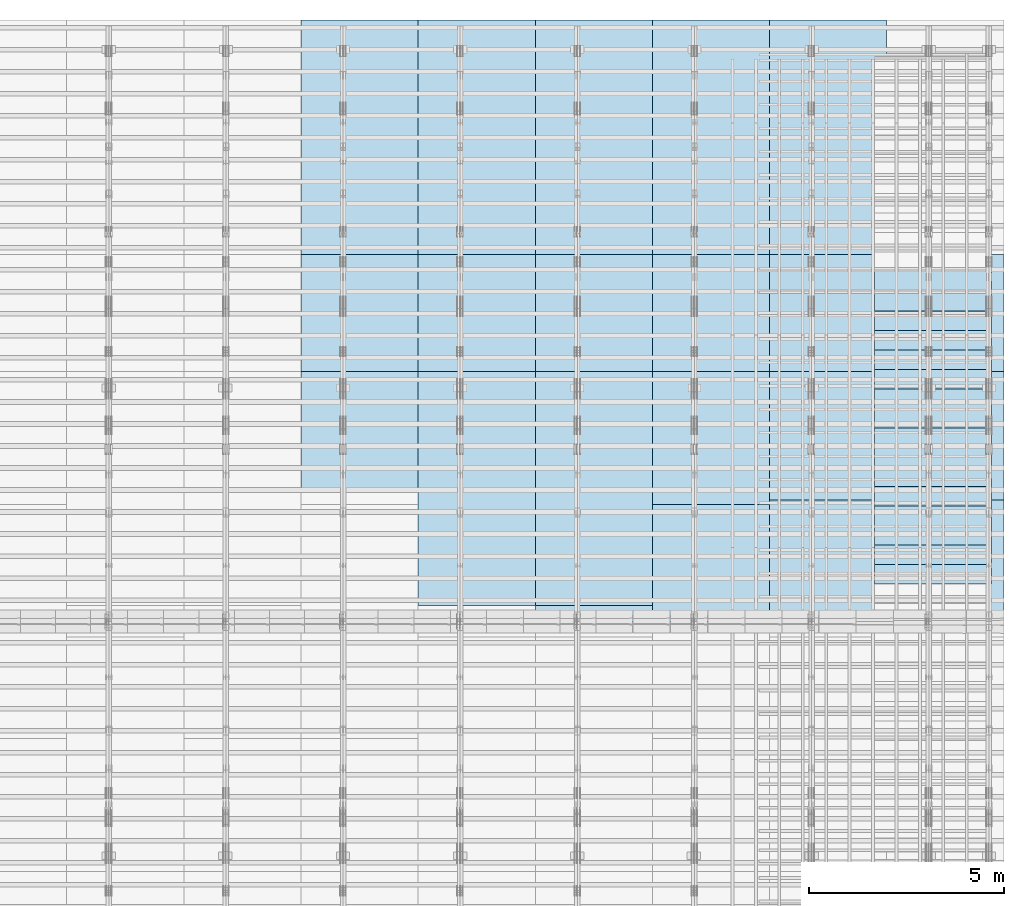
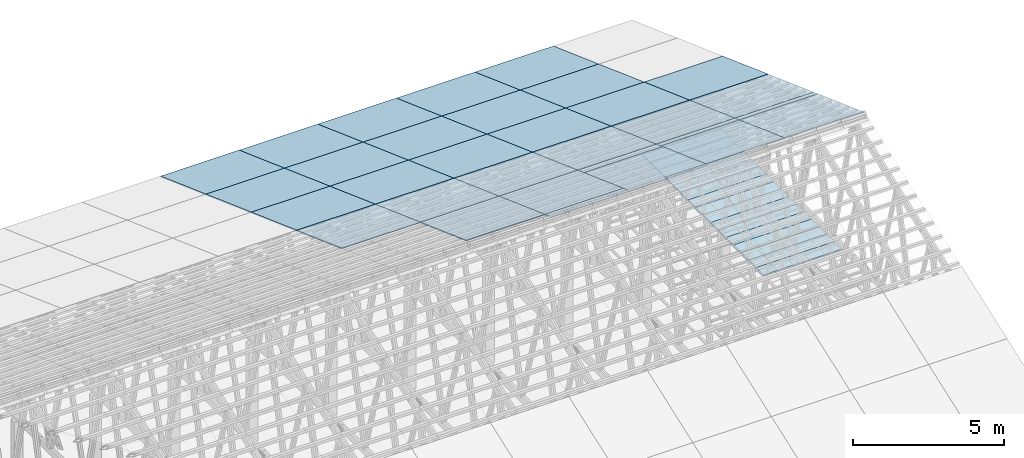
# One storey, part 10 of 189: 47 slabs, 47 elements without a shape of their own.
"""IFC2X3 building model written with IfcOpenShell, lengths in millimetres."""

from ifc_helpers import new_model, entity, si_unit, converted_unit, derived_unit, direction, frame, frame_2d, origin, origin_2d_with_axis, place, context, subcontext, project, spatial, rectangle, extrude, material, layer, layer_set, element, aggregate, save


model = new_model("IFC2X3")

# Units and contexts
model_context = context("Model", 3, precision=0.01, world=origin(), true_north=direction((6.12303176911189e-17, 1.0)))
body_context = subcontext(model_context, "Body", "Model", "MODEL_VIEW")
ifc_project = project(units=[si_unit("LENGTHUNIT", "METRE", prefix="MILLI"), si_unit("AREAUNIT", "SQUARE_METRE"), si_unit("VOLUMEUNIT", "CUBIC_METRE"), converted_unit("PLANEANGLEUNIT", "DEGREE", entity("IfcRatioMeasure", 0.0174532925199433), si_unit("PLANEANGLEUNIT", "RADIAN"), dimensions=[0, 0, 0, 0, 0, 0, 0]), si_unit("MASSUNIT", "GRAM", prefix="KILO"), derived_unit("MASSDENSITYUNIT", [(si_unit("MASSUNIT", "GRAM", prefix="KILO"), 1), (si_unit("LENGTHUNIT", "METRE"), -3)]), si_unit("TIMEUNIT", "SECOND"), si_unit("FREQUENCYUNIT", "HERTZ"), si_unit("THERMODYNAMICTEMPERATUREUNIT", "DEGREE_CELSIUS"), derived_unit("THERMALTRANSMITTANCEUNIT", [(si_unit("MASSUNIT", "GRAM", prefix="KILO"), 1), (si_unit("THERMODYNAMICTEMPERATUREUNIT", "KELVIN"), -1), (si_unit("TIMEUNIT", "SECOND"), -3)]), derived_unit("VOLUMETRICFLOWRATEUNIT", [(si_unit("LENGTHUNIT", "METRE"), 3), (si_unit("TIMEUNIT", "SECOND"), -1)]), si_unit("ELECTRICCURRENTUNIT", "AMPERE"), si_unit("ELECTRICVOLTAGEUNIT", "VOLT"), si_unit("POWERUNIT", "WATT"), si_unit("FORCEUNIT", "NEWTON"), si_unit("ILLUMINANCEUNIT", "LUX"), si_unit("LUMINOUSFLUXUNIT", "LUMEN"), si_unit("LUMINOUSINTENSITYUNIT", "CANDELA"), derived_unit("USERDEFINED", [(si_unit("MASSUNIT", "GRAM", prefix="KILO"), -1), (si_unit("LENGTHUNIT", "METRE"), -2), (si_unit("TIMEUNIT", "SECOND"), 3), (si_unit("LUMINOUSFLUXUNIT", "LUMEN"), 1)]), derived_unit("LINEARVELOCITYUNIT", [(si_unit("LENGTHUNIT", "METRE"), 1), (si_unit("TIMEUNIT", "SECOND"), -1)]), si_unit("PRESSUREUNIT", "PASCAL"), derived_unit("USERDEFINED", [(si_unit("LENGTHUNIT", "METRE"), -2), (si_unit("MASSUNIT", "GRAM", prefix="KILO"), 1), (si_unit("TIMEUNIT", "SECOND"), -2)])], contexts=[model_context])

# Site, building, storey
site_placement = place(None, origin())
site = spatial("IfcSite", under=ifc_project, at=site_placement, CompositionType="ELEMENT")
building_placement = place(site_placement, origin())
building = spatial("IfcBuilding", under=site, at=building_placement, CompositionType="ELEMENT")
storey_placement = place(building_placement, origin())
storey = spatial("IfcBuildingStorey", under=building, at=storey_placement, Name="Default", CompositionType="ELEMENT", Elevation=0.0)

# Roof, slab
roof_1_placement = place(storey_placement, frame((47153.4200853155, 21152.222636977, 2421.93662132902)))
roof_1 = element("IfcRoof", 1, at=roof_1_placement, inside=storey, ShapeType="NOTDEFINED")
ifc_material_1 = material()
ifc_layer_1 = layer(ifc_material_1, 40.0)
ifc_layer_set_1 = layer_set([ifc_layer_1])
slab_1_placement = place(roof_1_placement, origin())
slab_1 = element("IfcSlab", 2, at=slab_1_placement, material=ifc_layer_set_1, PredefinedType="ROOF", context=body_context, shape_type="SweptSolid", body=[
    extrude(rectangle(XDim=3192.53331742773, YDim=3000.0, at=frame_2d((4.32009983342141e-12, 1.13686837721616e-13), x_axis=(0.0, 1.0))), frame((1500.0, 1500.0, 545.955351399304), z_axis=(0.0, 0.342020143325669, 0.939692620785908), x_axis=(1.0, 0.0, 0.0)), (0.0, -0.342020143325669, 0.939692620785908), 42.5671108990361),
])
aggregate(roof_1, [slab_1])

roof_2_placement = place(storey_placement, frame((47153.4200853155, 18152.222636977, 3513.84732412761)))
roof_2 = element("IfcRoof", 3, at=roof_2_placement, inside=storey, ShapeType="NOTDEFINED")
slab_2_placement = place(roof_2_placement, origin())
slab_2 = element("IfcSlab", 4, at=slab_2_placement, material=ifc_layer_set_1, PredefinedType="ROOF", context=body_context, shape_type="SweptSolid", body=[
    extrude(rectangle(XDim=3192.53331742773, YDim=3000.0, at=frame_2d((4.32009983342141e-12, 0.0), x_axis=(0.0, 1.0))), frame((1500.0, 1500.0, 545.955351399303), z_axis=(0.0, 0.342020143325669, 0.939692620785908), x_axis=(1.0, 0.0, 0.0)), (0.0, -0.342020143325669, 0.939692620785908), 42.5671108990366),
])
aggregate(roof_2, [slab_2])

roof_3_placement = place(storey_placement, frame((47153.4200853155, 15152.222636977, 4605.75802692621)))
roof_3 = element("IfcRoof", 5, at=roof_3_placement, inside=storey, ShapeType="NOTDEFINED")
slab_3_placement = place(roof_3_placement, origin())
slab_3 = element("IfcSlab", 6, at=slab_3_placement, material=ifc_layer_set_1, PredefinedType="ROOF", context=body_context, shape_type="SweptSolid", body=[
    extrude(rectangle(XDim=3192.53331742773, YDim=3000.0, at=frame_2d((4.32009983342141e-12, -1.13686837721616e-13), x_axis=(0.0, 1.0))), frame((1500.0, 1500.0, 545.955351399304), z_axis=(0.0, 0.342020143325669, 0.939692620785908), x_axis=(1.0, 0.0, 0.0)), (0.0, -0.342020143325669, 0.939692620785908), 42.5671108990361),
])
aggregate(roof_3, [slab_3])

roof_4_placement = place(storey_placement, frame((47153.4200853155, 14853.3662321495, 4714.53286260321)))
roof_4 = element("IfcRoof", 7, at=roof_4_placement, inside=storey, ShapeType="NOTDEFINED")
slab_4_placement = place(roof_4_placement, origin())
slab_4 = element("IfcSlab", 8, at=slab_4_placement, material=ifc_layer_set_1, PredefinedType="ROOF", context=body_context, shape_type="SweptSolid", body=[
    extrude(rectangle(XDim=3192.53331742773, YDim=3000.0, at=frame_2d((4.32009983342141e-12, 0.0), x_axis=(0.0, 1.0))), frame((1500.0, 1500.0, 545.955351399303), z_axis=(0.0, 0.342020143325669, 0.939692620785908), x_axis=(1.0, 0.0, 0.0)), (0.0, -0.342020143325669, 0.939692620785908), 42.5671108990372),
])
aggregate(roof_4, [slab_4])

roof_5_placement = place(storey_placement, frame((44153.4200853155, 27152.222636977, 238.115215731819)))
roof_5 = element("IfcRoof", 9, at=roof_5_placement, inside=storey, ShapeType="NOTDEFINED")
slab_5_placement = place(roof_5_placement, origin())
slab_5 = element("IfcSlab", 10, at=slab_5_placement, material=ifc_layer_set_1, PredefinedType="ROOF", context=body_context, shape_type="SweptSolid", body=[
    extrude(rectangle(XDim=3192.53331742773, YDim=2999.99999999999, at=frame_2d((0.0, 1.13686837721616e-13), x_axis=(0.0, 1.0))), frame((1500.0, 1500.0, 545.955351399304), z_axis=(0.0, 0.342020143325669, 0.939692620785908), x_axis=(1.0, 0.0, 0.0)), (0.0, -0.342020143325669, 0.939692620785908), 42.5671108990364),
])
aggregate(roof_5, [slab_5])

roof_6_placement = place(storey_placement, frame((44153.4200853155, 24152.222636977, 1330.02591853042)))
roof_6 = element("IfcRoof", 11, at=roof_6_placement, inside=storey, ShapeType="NOTDEFINED")
slab_6_placement = place(roof_6_placement, origin())
slab_6 = element("IfcSlab", 12, at=slab_6_placement, material=ifc_layer_set_1, PredefinedType="ROOF", context=body_context, shape_type="SweptSolid", body=[
    extrude(rectangle(XDim=3192.53331742773, YDim=2999.99999999999, at=frame_2d((0.0, 0.0), x_axis=(0.0, 1.0))), frame((1500.0, 1500.0, 545.955351399304), z_axis=(0.0, 0.342020143325669, 0.939692620785908), x_axis=(1.0, 0.0, 0.0)), (0.0, -0.342020143325669, 0.939692620785908), 42.5671108990358),
])
aggregate(roof_6, [slab_6])

roof_7_placement = place(storey_placement, frame((44153.4200853155, 21152.222636977, 2421.93662132902)))
roof_7 = element("IfcRoof", 13, at=roof_7_placement, inside=storey, ShapeType="NOTDEFINED")
slab_7_placement = place(roof_7_placement, origin())
slab_7 = element("IfcSlab", 14, at=slab_7_placement, material=ifc_layer_set_1, PredefinedType="ROOF", context=body_context, shape_type="SweptSolid", body=[
    extrude(rectangle(XDim=3192.53331742773, YDim=3000.0, at=frame_2d((4.32009983342141e-12, 1.13686837721616e-13), x_axis=(0.0, 1.0))), frame((1500.0, 1500.0, 545.955351399304), z_axis=(0.0, 0.342020143325669, 0.939692620785908), x_axis=(1.0, 0.0, 0.0)), (0.0, -0.342020143325669, 0.939692620785908), 42.5671108990361),
])
aggregate(roof_7, [slab_7])

roof_8_placement = place(storey_placement, frame((44153.4200853155, 18152.222636977, 3513.84732412761)))
roof_8 = element("IfcRoof", 15, at=roof_8_placement, inside=storey, ShapeType="NOTDEFINED")
slab_8_placement = place(roof_8_placement, origin())
slab_8 = element("IfcSlab", 16, at=slab_8_placement, material=ifc_layer_set_1, PredefinedType="ROOF", context=body_context, shape_type="SweptSolid", body=[
    extrude(rectangle(XDim=3192.53331742773, YDim=3000.0, at=frame_2d((4.32009983342141e-12, 0.0), x_axis=(0.0, 1.0))), frame((1500.0, 1500.0, 545.955351399303), z_axis=(0.0, 0.342020143325669, 0.939692620785908), x_axis=(1.0, 0.0, 0.0)), (0.0, -0.342020143325669, 0.939692620785908), 42.5671108990366),
])
aggregate(roof_8, [slab_8])

roof_9_placement = place(storey_placement, frame((44153.4200853155, 15152.222636977, 4605.75802692621)))
roof_9 = element("IfcRoof", 17, at=roof_9_placement, inside=storey, ShapeType="NOTDEFINED")
slab_9_placement = place(roof_9_placement, origin())
slab_9 = element("IfcSlab", 18, at=slab_9_placement, material=ifc_layer_set_1, PredefinedType="ROOF", context=body_context, shape_type="SweptSolid", body=[
    extrude(rectangle(XDim=3192.53331742773, YDim=3000.0, at=frame_2d((4.32009983342141e-12, -1.13686837721616e-13), x_axis=(0.0, 1.0))), frame((1500.0, 1500.0, 545.955351399304), z_axis=(0.0, 0.342020143325669, 0.939692620785908), x_axis=(1.0, 0.0, 0.0)), (0.0, -0.342020143325669, 0.939692620785908), 42.5671108990361),
])
aggregate(roof_9, [slab_9])

roof_10_placement = place(storey_placement, frame((44153.4200853155, 14853.3662321495, 4714.53286260321)))
roof_10 = element("IfcRoof", 19, at=roof_10_placement, inside=storey, ShapeType="NOTDEFINED")
slab_10_placement = place(roof_10_placement, origin())
slab_10 = element("IfcSlab", 20, at=slab_10_placement, material=ifc_layer_set_1, PredefinedType="ROOF", context=body_context, shape_type="SweptSolid", body=[
    extrude(rectangle(XDim=3192.53331742773, YDim=3000.0, at=frame_2d((4.32009983342141e-12, 0.0), x_axis=(0.0, 1.0))), frame((1500.0, 1500.0, 545.955351399303), z_axis=(0.0, 0.342020143325669, 0.939692620785908), x_axis=(1.0, 0.0, 0.0)), (0.0, -0.342020143325669, 0.939692620785908), 42.5671108990372),
])
aggregate(roof_10, [slab_10])

roof_11_placement = place(storey_placement, frame((41153.4200853155, 27152.222636977, 238.115215731819)))
roof_11 = element("IfcRoof", 21, at=roof_11_placement, inside=storey, ShapeType="NOTDEFINED")
slab_11_placement = place(roof_11_placement, origin())
slab_11 = element("IfcSlab", 22, at=slab_11_placement, material=ifc_layer_set_1, PredefinedType="ROOF", context=body_context, shape_type="SweptSolid", body=[
    extrude(rectangle(XDim=3192.53331742773, YDim=2999.99999999999, at=frame_2d((0.0, 1.13686837721616e-13), x_axis=(0.0, 1.0))), frame((1500.0, 1500.0, 545.955351399304), z_axis=(0.0, 0.342020143325669, 0.939692620785908), x_axis=(1.0, 0.0, 0.0)), (0.0, -0.342020143325669, 0.939692620785908), 42.5671108990364),
])
aggregate(roof_11, [slab_11])

roof_12_placement = place(storey_placement, frame((41153.4200853155, 24152.222636977, 1330.02591853042)))
roof_12 = element("IfcRoof", 23, at=roof_12_placement, inside=storey, ShapeType="NOTDEFINED")
slab_12_placement = place(roof_12_placement, origin())
slab_12 = element("IfcSlab", 24, at=slab_12_placement, material=ifc_layer_set_1, PredefinedType="ROOF", context=body_context, shape_type="SweptSolid", body=[
    extrude(rectangle(XDim=3192.53331742773, YDim=2999.99999999999, at=frame_2d((0.0, 0.0), x_axis=(0.0, 1.0))), frame((1500.0, 1500.0, 545.955351399304), z_axis=(0.0, 0.342020143325669, 0.939692620785908), x_axis=(1.0, 0.0, 0.0)), (0.0, -0.342020143325669, 0.939692620785908), 42.5671108990358),
])
aggregate(roof_12, [slab_12])

roof_13_placement = place(storey_placement, frame((41153.4200853155, 21152.222636977, 2421.93662132902)))
roof_13 = element("IfcRoof", 25, at=roof_13_placement, inside=storey, ShapeType="NOTDEFINED")
slab_13_placement = place(roof_13_placement, origin())
slab_13 = element("IfcSlab", 26, at=slab_13_placement, material=ifc_layer_set_1, PredefinedType="ROOF", context=body_context, shape_type="SweptSolid", body=[
    extrude(rectangle(XDim=3192.53331742773, YDim=3000.0, at=frame_2d((4.32009983342141e-12, 1.13686837721616e-13), x_axis=(0.0, 1.0))), frame((1500.0, 1500.0, 545.955351399304), z_axis=(0.0, 0.342020143325669, 0.939692620785908), x_axis=(1.0, 0.0, 0.0)), (0.0, -0.342020143325669, 0.939692620785908), 42.5671108990361),
])
aggregate(roof_13, [slab_13])

roof_14_placement = place(storey_placement, frame((41153.4200853155, 18152.222636977, 3513.84732412761)))
roof_14 = element("IfcRoof", 27, at=roof_14_placement, inside=storey, ShapeType="NOTDEFINED")
slab_14_placement = place(roof_14_placement, origin())
slab_14 = element("IfcSlab", 28, at=slab_14_placement, material=ifc_layer_set_1, PredefinedType="ROOF", context=body_context, shape_type="SweptSolid", body=[
    extrude(rectangle(XDim=3192.53331742773, YDim=3000.0, at=frame_2d((4.32009983342141e-12, 0.0), x_axis=(0.0, 1.0))), frame((1500.0, 1500.0, 545.955351399303), z_axis=(0.0, 0.342020143325669, 0.939692620785908), x_axis=(1.0, 0.0, 0.0)), (0.0, -0.342020143325669, 0.939692620785908), 42.5671108990366),
])
aggregate(roof_14, [slab_14])

roof_15_placement = place(storey_placement, frame((41153.4200853155, 15152.222636977, 4605.75802692621)))
roof_15 = element("IfcRoof", 29, at=roof_15_placement, inside=storey, ShapeType="NOTDEFINED")
slab_15_placement = place(roof_15_placement, origin())
slab_15 = element("IfcSlab", 30, at=slab_15_placement, material=ifc_layer_set_1, PredefinedType="ROOF", context=body_context, shape_type="SweptSolid", body=[
    extrude(rectangle(XDim=3192.53331742773, YDim=3000.0, at=frame_2d((4.32009983342141e-12, -1.13686837721616e-13), x_axis=(0.0, 1.0))), frame((1500.0, 1500.0, 545.955351399304), z_axis=(0.0, 0.342020143325669, 0.939692620785908), x_axis=(1.0, 0.0, 0.0)), (0.0, -0.342020143325669, 0.939692620785908), 42.5671108990361),
])
aggregate(roof_15, [slab_15])

roof_16_placement = place(storey_placement, frame((41153.4200853155, 14750.0000438631, 4752.15507836903)))
roof_16 = element("IfcRoof", 31, at=roof_16_placement, inside=storey, ShapeType="NOTDEFINED")
slab_16_placement = place(roof_16_placement, origin())
slab_16 = element("IfcSlab", 32, at=slab_16_placement, material=ifc_layer_set_1, PredefinedType="ROOF", context=body_context, shape_type="SweptSolid", body=[
    extrude(rectangle(XDim=3192.53331742773, YDim=3000.0, at=frame_2d((4.32009983342141e-12, -1.13686837721616e-13), x_axis=(0.0, 1.0))), frame((1500.0, 1500.0, 545.955351399304), z_axis=(0.0, 0.342020143325669, 0.939692620785908), x_axis=(1.0, 0.0, 0.0)), (0.0, -0.342020143325669, 0.939692620785908), 42.5671108990361),
])
aggregate(roof_16, [slab_16])

roof_17_placement = place(storey_placement, frame((38153.4200853156, 27152.222636977, 238.115215731819)))
roof_17 = element("IfcRoof", 33, at=roof_17_placement, inside=storey, ShapeType="NOTDEFINED")
slab_17_placement = place(roof_17_placement, origin())
slab_17 = element("IfcSlab", 34, at=slab_17_placement, material=ifc_layer_set_1, PredefinedType="ROOF", context=body_context, shape_type="SweptSolid", body=[
    extrude(rectangle(XDim=3192.53331742773, YDim=2999.99999999999, at=frame_2d((-2.1600499167107e-12, 1.13686837721616e-13), x_axis=(0.0, 1.0))), frame((1500.0, 1500.0, 545.955351399304), z_axis=(0.0, 0.342020143325669, 0.939692620785908), x_axis=(1.0, 0.0, 0.0)), (0.0, -0.342020143325669, 0.939692620785908), 42.5671108990364),
])
aggregate(roof_17, [slab_17])

roof_18_placement = place(storey_placement, frame((38153.4200853155, 24152.222636977, 1330.02591853042)))
roof_18 = element("IfcRoof", 35, at=roof_18_placement, inside=storey, ShapeType="NOTDEFINED")
slab_18_placement = place(roof_18_placement, origin())
slab_18 = element("IfcSlab", 36, at=slab_18_placement, material=ifc_layer_set_1, PredefinedType="ROOF", context=body_context, shape_type="SweptSolid", body=[
    extrude(rectangle(XDim=3192.53331742773, YDim=2999.99999999999, at=frame_2d((-2.1600499167107e-12, 0.0), x_axis=(0.0, 1.0))), frame((1500.0, 1500.0, 545.955351399304), z_axis=(0.0, 0.342020143325669, 0.939692620785908), x_axis=(1.0, 0.0, 0.0)), (0.0, -0.342020143325669, 0.939692620785908), 42.5671108990358),
])
aggregate(roof_18, [slab_18])

roof_19_placement = place(storey_placement, frame((38153.4200853155, 21152.222636977, 2421.93662132902)))
roof_19 = element("IfcRoof", 37, at=roof_19_placement, inside=storey, ShapeType="NOTDEFINED")
slab_19_placement = place(roof_19_placement, origin())
slab_19 = element("IfcSlab", 38, at=slab_19_placement, material=ifc_layer_set_1, PredefinedType="ROOF", context=body_context, shape_type="SweptSolid", body=[
    extrude(rectangle(XDim=3192.53331742773, YDim=3000.0, at=frame_2d((2.1600499167107e-12, 1.13686837721616e-13), x_axis=(0.0, 1.0))), frame((1500.0, 1500.0, 545.955351399304), z_axis=(0.0, 0.342020143325669, 0.939692620785908), x_axis=(1.0, 0.0, 0.0)), (0.0, -0.342020143325669, 0.939692620785908), 42.5671108990361),
])
aggregate(roof_19, [slab_19])

roof_20_placement = place(storey_placement, frame((38153.4200853155, 18152.222636977, 3513.84732412761)))
roof_20 = element("IfcRoof", 39, at=roof_20_placement, inside=storey, ShapeType="NOTDEFINED")
slab_20_placement = place(roof_20_placement, origin())
slab_20 = element("IfcSlab", 40, at=slab_20_placement, material=ifc_layer_set_1, PredefinedType="ROOF", context=body_context, shape_type="SweptSolid", body=[
    extrude(rectangle(XDim=3192.53331742773, YDim=3000.0, at=frame_2d((2.1600499167107e-12, 0.0), x_axis=(0.0, 1.0))), frame((1500.0, 1500.0, 545.955351399303), z_axis=(0.0, 0.342020143325669, 0.939692620785908), x_axis=(1.0, 0.0, 0.0)), (0.0, -0.342020143325669, 0.939692620785908), 42.5671108990366),
])
aggregate(roof_20, [slab_20])

roof_21_placement = place(storey_placement, frame((38153.4200853155, 15152.222636977, 4605.75802692621)))
roof_21 = element("IfcRoof", 41, at=roof_21_placement, inside=storey, ShapeType="NOTDEFINED")
slab_21_placement = place(roof_21_placement, origin())
slab_21 = element("IfcSlab", 42, at=slab_21_placement, material=ifc_layer_set_1, PredefinedType="ROOF", context=body_context, shape_type="SweptSolid", body=[
    extrude(rectangle(XDim=3192.53331742773, YDim=3000.0, at=frame_2d((2.1600499167107e-12, -1.13686837721616e-13), x_axis=(0.0, 1.0))), frame((1500.0, 1500.0, 545.955351399304), z_axis=(0.0, 0.342020143325669, 0.939692620785908), x_axis=(1.0, 0.0, 0.0)), (0.0, -0.342020143325669, 0.939692620785908), 42.5671108990361),
])
aggregate(roof_21, [slab_21])

roof_22_placement = place(storey_placement, frame((38153.4200853155, 14750.0000438631, 4752.15507836903)))
roof_22 = element("IfcRoof", 43, at=roof_22_placement, inside=storey, ShapeType="NOTDEFINED")
slab_22_placement = place(roof_22_placement, origin())
slab_22 = element("IfcSlab", 44, at=slab_22_placement, material=ifc_layer_set_1, PredefinedType="ROOF", context=body_context, shape_type="SweptSolid", body=[
    extrude(rectangle(XDim=3192.53331742773, YDim=3000.0, at=frame_2d((2.1600499167107e-12, -1.13686837721616e-13), x_axis=(0.0, 1.0))), frame((1500.0, 1500.0, 545.955351399304), z_axis=(0.0, 0.342020143325669, 0.939692620785908), x_axis=(1.0, 0.0, 0.0)), (0.0, -0.342020143325669, 0.939692620785908), 42.5671108990361),
])
aggregate(roof_22, [slab_22])

roof_23_placement = place(storey_placement, frame((35153.4200853156, 27152.222636977, 238.115215731819)))
roof_23 = element("IfcRoof", 45, at=roof_23_placement, inside=storey, ShapeType="NOTDEFINED")
slab_23_placement = place(roof_23_placement, origin())
slab_23 = element("IfcSlab", 46, at=slab_23_placement, material=ifc_layer_set_1, PredefinedType="ROOF", context=body_context, shape_type="SweptSolid", body=[
    extrude(rectangle(XDim=3192.53331742773, YDim=2999.99999999999, at=frame_2d((-2.1600499167107e-12, 1.13686837721616e-13), x_axis=(0.0, 1.0))), frame((1500.0, 1500.0, 545.955351399304), z_axis=(0.0, 0.342020143325669, 0.939692620785908), x_axis=(1.0, 0.0, 0.0)), (0.0, -0.342020143325669, 0.939692620785908), 42.5671108990364),
])
aggregate(roof_23, [slab_23])

roof_24_placement = place(storey_placement, frame((35153.4200853156, 24152.222636977, 1330.02591853042)))
roof_24 = element("IfcRoof", 47, at=roof_24_placement, inside=storey, ShapeType="NOTDEFINED")
slab_24_placement = place(roof_24_placement, origin())
slab_24 = element("IfcSlab", 48, at=slab_24_placement, material=ifc_layer_set_1, PredefinedType="ROOF", context=body_context, shape_type="SweptSolid", body=[
    extrude(rectangle(XDim=3192.53331742773, YDim=2999.99999999999, at=frame_2d((-2.1600499167107e-12, 0.0), x_axis=(0.0, 1.0))), frame((1500.0, 1500.0, 545.955351399304), z_axis=(0.0, 0.342020143325669, 0.939692620785908), x_axis=(1.0, 0.0, 0.0)), (0.0, -0.342020143325669, 0.939692620785908), 42.5671108990358),
])
aggregate(roof_24, [slab_24])

roof_25_placement = place(storey_placement, frame((35153.4200853156, 21152.222636977, 2421.93662132902)))
roof_25 = element("IfcRoof", 49, at=roof_25_placement, inside=storey, ShapeType="NOTDEFINED")
slab_25_placement = place(roof_25_placement, origin())
slab_25 = element("IfcSlab", 50, at=slab_25_placement, material=ifc_layer_set_1, PredefinedType="ROOF", context=body_context, shape_type="SweptSolid", body=[
    extrude(rectangle(XDim=3192.53331742773, YDim=3000.0, at=frame_2d((2.1600499167107e-12, 1.13686837721616e-13), x_axis=(0.0, 1.0))), frame((1500.0, 1500.0, 545.955351399304), z_axis=(0.0, 0.342020143325669, 0.939692620785908), x_axis=(1.0, 0.0, 0.0)), (0.0, -0.342020143325669, 0.939692620785908), 42.5671108990361),
])
aggregate(roof_25, [slab_25])

roof_26_placement = place(storey_placement, frame((35153.4200853156, 18152.222636977, 3513.84732412761)))
roof_26 = element("IfcRoof", 51, at=roof_26_placement, inside=storey, ShapeType="NOTDEFINED")
slab_26_placement = place(roof_26_placement, origin())
slab_26 = element("IfcSlab", 52, at=slab_26_placement, material=ifc_layer_set_1, PredefinedType="ROOF", context=body_context, shape_type="SweptSolid", body=[
    extrude(rectangle(XDim=3192.53331742773, YDim=3000.0, at=frame_2d((2.1600499167107e-12, 0.0), x_axis=(0.0, 1.0))), frame((1500.0, 1500.0, 545.955351399303), z_axis=(0.0, 0.342020143325669, 0.939692620785908), x_axis=(1.0, 0.0, 0.0)), (0.0, -0.342020143325669, 0.939692620785908), 42.5671108990366),
])
aggregate(roof_26, [slab_26])

roof_27_placement = place(storey_placement, frame((35153.4200853156, 15152.222636977, 4605.75802692621)))
roof_27 = element("IfcRoof", 53, at=roof_27_placement, inside=storey, ShapeType="NOTDEFINED")
slab_27_placement = place(roof_27_placement, origin())
slab_27 = element("IfcSlab", 54, at=slab_27_placement, material=ifc_layer_set_1, PredefinedType="ROOF", context=body_context, shape_type="SweptSolid", body=[
    extrude(rectangle(XDim=3192.53331742773, YDim=3000.0, at=frame_2d((2.1600499167107e-12, -1.13686837721616e-13), x_axis=(0.0, 1.0))), frame((1500.0, 1500.0, 545.955351399304), z_axis=(0.0, 0.342020143325669, 0.939692620785908), x_axis=(1.0, 0.0, 0.0)), (0.0, -0.342020143325669, 0.939692620785908), 42.5671108990361),
])
aggregate(roof_27, [slab_27])

roof_28_placement = place(storey_placement, frame((32153.4200853156, 27152.222636977, 238.115215731819)))
roof_28 = element("IfcRoof", 55, at=roof_28_placement, inside=storey, ShapeType="NOTDEFINED")
slab_28_placement = place(roof_28_placement, origin())
slab_28 = element("IfcSlab", 56, at=slab_28_placement, material=ifc_layer_set_1, PredefinedType="ROOF", context=body_context, shape_type="SweptSolid", body=[
    extrude(rectangle(XDim=3192.53331742773, YDim=2999.99999999999, at=frame_2d((-2.1600499167107e-12, 1.13686837721616e-13), x_axis=(0.0, 1.0))), frame((1500.0, 1500.0, 545.955351399304), z_axis=(0.0, 0.342020143325669, 0.939692620785908), x_axis=(1.0, 0.0, 0.0)), (0.0, -0.342020143325669, 0.939692620785908), 42.5671108990364),
])
aggregate(roof_28, [slab_28])

roof_29_placement = place(storey_placement, frame((32153.4200853156, 24152.222636977, 1330.02591853042)))
roof_29 = element("IfcRoof", 57, at=roof_29_placement, inside=storey, ShapeType="NOTDEFINED")
slab_29_placement = place(roof_29_placement, origin())
slab_29 = element("IfcSlab", 58, at=slab_29_placement, material=ifc_layer_set_1, PredefinedType="ROOF", context=body_context, shape_type="SweptSolid", body=[
    extrude(rectangle(XDim=3192.53331742773, YDim=2999.99999999999, at=frame_2d((-2.1600499167107e-12, 0.0), x_axis=(0.0, 1.0))), frame((1500.0, 1500.0, 545.955351399304), z_axis=(0.0, 0.342020143325669, 0.939692620785908), x_axis=(1.0, 0.0, 0.0)), (0.0, -0.342020143325669, 0.939692620785908), 42.5671108990358),
])
aggregate(roof_29, [slab_29])

roof_30_placement = place(storey_placement, frame((32153.4200853156, 21152.222636977, 2421.93662132902)))
roof_30 = element("IfcRoof", 59, at=roof_30_placement, inside=storey, ShapeType="NOTDEFINED")
slab_30_placement = place(roof_30_placement, origin())
slab_30 = element("IfcSlab", 60, at=slab_30_placement, material=ifc_layer_set_1, PredefinedType="ROOF", context=body_context, shape_type="SweptSolid", body=[
    extrude(rectangle(XDim=3192.53331742773, YDim=3000.0, at=frame_2d((2.1600499167107e-12, 1.13686837721616e-13), x_axis=(0.0, 1.0))), frame((1500.0, 1500.0, 545.955351399304), z_axis=(0.0, 0.342020143325669, 0.939692620785908), x_axis=(1.0, 0.0, 0.0)), (0.0, -0.342020143325669, 0.939692620785908), 42.5671108990361),
])
aggregate(roof_30, [slab_30])

roof_31_placement = place(storey_placement, frame((32153.4200853156, 18152.222636977, 3513.84732412761)))
roof_31 = element("IfcRoof", 61, at=roof_31_placement, inside=storey, ShapeType="NOTDEFINED")
slab_31_placement = place(roof_31_placement, origin())
slab_31 = element("IfcSlab", 62, at=slab_31_placement, material=ifc_layer_set_1, PredefinedType="ROOF", context=body_context, shape_type="SweptSolid", body=[
    extrude(rectangle(XDim=3192.53331742773, YDim=3000.0, at=frame_2d((2.1600499167107e-12, 0.0), x_axis=(0.0, 1.0))), frame((1500.0, 1500.0, 545.955351399303), z_axis=(0.0, 0.342020143325669, 0.939692620785908), x_axis=(1.0, 0.0, 0.0)), (0.0, -0.342020143325669, 0.939692620785908), 42.5671108990366),
])
aggregate(roof_31, [slab_31])

roof_32_placement = place(storey_placement, frame((46837.7477027695, 15705.0, -150.0)))
roof_32 = element("IfcRoof", 63, at=roof_32_placement, inside=storey, ShapeType="NOTDEFINED")
ifc_material_2 = material(Name="NLRS_n7_isolatie MegaPlus_Kingspan")
ifc_layer_2 = layer(ifc_material_2, 60.0)
ifc_layer_set_2 = layer_set([ifc_layer_2])
slab_32_placement = place(roof_32_placement, origin())
slab_32 = element("IfcSlab", 64, at=slab_32_placement, material=ifc_layer_set_2, PredefinedType="ROOF", context=body_context, shape_type="SweptSolid", body=[
    extrude(rectangle(XDim=3000.00000000001, YDim=499.99999999999, at=origin_2d_with_axis()), frame((1500.0, 250.0, 0.0)), (0.0, 0.0, 1.0), 60.0),
])
aggregate(roof_32, [slab_32])

roof_33_placement = place(storey_placement, frame((46837.7477027695, 16205.0, -150.0)))
roof_33 = element("IfcRoof", 65, at=roof_33_placement, inside=storey, ShapeType="NOTDEFINED")
slab_33_placement = place(roof_33_placement, origin())
slab_33 = element("IfcSlab", 66, at=slab_33_placement, material=ifc_layer_set_2, PredefinedType="ROOF", context=body_context, shape_type="SweptSolid", body=[
    extrude(rectangle(XDim=3000.00000000001, YDim=499.99999999999, at=origin_2d_with_axis()), frame((1500.0, 250.0, 0.0)), (0.0, 0.0, 1.0), 60.0),
])
aggregate(roof_33, [slab_33])

roof_34_placement = place(storey_placement, frame((46837.7477027695, 16705.0, -150.0)))
roof_34 = element("IfcRoof", 67, at=roof_34_placement, inside=storey, ShapeType="NOTDEFINED")
slab_34_placement = place(roof_34_placement, origin())
slab_34 = element("IfcSlab", 68, at=slab_34_placement, material=ifc_layer_set_2, PredefinedType="ROOF", context=body_context, shape_type="SweptSolid", body=[
    extrude(rectangle(XDim=3000.00000000001, YDim=499.99999999999, at=origin_2d_with_axis()), frame((1500.0, 250.0, 0.0)), (0.0, 0.0, 1.0), 60.0),
])
aggregate(roof_34, [slab_34])

roof_35_placement = place(storey_placement, frame((46837.7477027695, 17205.0, -150.0)))
roof_35 = element("IfcRoof", 69, at=roof_35_placement, inside=storey, ShapeType="NOTDEFINED")
slab_35_placement = place(roof_35_placement, origin())
slab_35 = element("IfcSlab", 70, at=slab_35_placement, material=ifc_layer_set_2, PredefinedType="ROOF", context=body_context, shape_type="SweptSolid", body=[
    extrude(rectangle(XDim=3000.00000000001, YDim=499.99999999999, at=origin_2d_with_axis()), frame((1500.0, 250.0, 0.0)), (0.0, 0.0, 1.0), 60.0),
])
aggregate(roof_35, [slab_35])

roof_36_placement = place(storey_placement, frame((46837.7477027695, 17705.0, -150.0)))
roof_36 = element("IfcRoof", 71, at=roof_36_placement, inside=storey, ShapeType="NOTDEFINED")
slab_36_placement = place(roof_36_placement, origin())
slab_36 = element("IfcSlab", 72, at=slab_36_placement, material=ifc_layer_set_2, PredefinedType="ROOF", context=body_context, shape_type="SweptSolid", body=[
    extrude(rectangle(XDim=3000.00000000001, YDim=499.99999999999, at=origin_2d_with_axis()), frame((1500.0, 250.0, 0.0)), (0.0, 0.0, 1.0), 60.0),
])
aggregate(roof_36, [slab_36])

roof_37_placement = place(storey_placement, frame((46837.7477027695, 18205.0, -150.0)))
roof_37 = element("IfcRoof", 73, at=roof_37_placement, inside=storey, ShapeType="NOTDEFINED")
slab_37_placement = place(roof_37_placement, origin())
slab_37 = element("IfcSlab", 74, at=slab_37_placement, material=ifc_layer_set_2, PredefinedType="ROOF", context=body_context, shape_type="SweptSolid", body=[
    extrude(rectangle(XDim=3000.00000000001, YDim=499.99999999999, at=origin_2d_with_axis()), frame((1500.0, 250.0, 0.0)), (0.0, 0.0, 1.0), 60.0),
])
aggregate(roof_37, [slab_37])

roof_38_placement = place(storey_placement, frame((46837.7477027695, 18705.0, -150.0)))
roof_38 = element("IfcRoof", 75, at=roof_38_placement, inside=storey, ShapeType="NOTDEFINED")
slab_38_placement = place(roof_38_placement, origin())
slab_38 = element("IfcSlab", 76, at=slab_38_placement, material=ifc_layer_set_2, PredefinedType="ROOF", context=body_context, shape_type="SweptSolid", body=[
    extrude(rectangle(XDim=3000.00000000001, YDim=499.99999999999, at=origin_2d_with_axis()), frame((1500.0, 250.0, 0.0)), (0.0, 0.0, 1.0), 60.0),
])
aggregate(roof_38, [slab_38])

roof_39_placement = place(storey_placement, frame((46837.7477027695, 19205.0, -150.0)))
roof_39 = element("IfcRoof", 77, at=roof_39_placement, inside=storey, ShapeType="NOTDEFINED")
slab_39_placement = place(roof_39_placement, origin())
slab_39 = element("IfcSlab", 78, at=slab_39_placement, material=ifc_layer_set_2, PredefinedType="ROOF", context=body_context, shape_type="SweptSolid", body=[
    extrude(rectangle(XDim=3000.00000000001, YDim=499.99999999999, at=origin_2d_with_axis()), frame((1500.0, 250.0, 0.0)), (0.0, 0.0, 1.0), 60.0),
])
aggregate(roof_39, [slab_39])

roof_40_placement = place(storey_placement, frame((46837.7477027695, 19705.0, -150.0)))
roof_40 = element("IfcRoof", 79, at=roof_40_placement, inside=storey, ShapeType="NOTDEFINED")
slab_40_placement = place(roof_40_placement, origin())
slab_40 = element("IfcSlab", 80, at=slab_40_placement, material=ifc_layer_set_2, PredefinedType="ROOF", context=body_context, shape_type="SweptSolid", body=[
    extrude(rectangle(XDim=3000.00000000001, YDim=499.99999999999, at=origin_2d_with_axis()), frame((1500.0, 250.0, 0.0)), (0.0, 0.0, 1.0), 60.0),
])
aggregate(roof_40, [slab_40])

roof_41_placement = place(storey_placement, frame((46837.7477027695, 20205.0, -150.0)))
roof_41 = element("IfcRoof", 81, at=roof_41_placement, inside=storey, ShapeType="NOTDEFINED")
slab_41_placement = place(roof_41_placement, origin())
slab_41 = element("IfcSlab", 82, at=slab_41_placement, material=ifc_layer_set_2, PredefinedType="ROOF", context=body_context, shape_type="SweptSolid", body=[
    extrude(rectangle(XDim=3000.00000000001, YDim=499.99999999999, at=origin_2d_with_axis()), frame((1500.0, 250.0, 0.0)), (0.0, 0.0, 1.0), 60.0),
])
aggregate(roof_41, [slab_41])

roof_42_placement = place(storey_placement, frame((46837.7477027695, 20705.0, -150.0)))
roof_42 = element("IfcRoof", 83, at=roof_42_placement, inside=storey, ShapeType="NOTDEFINED")
slab_42_placement = place(roof_42_placement, origin())
slab_42 = element("IfcSlab", 84, at=slab_42_placement, material=ifc_layer_set_2, PredefinedType="ROOF", context=body_context, shape_type="SweptSolid", body=[
    extrude(rectangle(XDim=3000.00000000001, YDim=499.99999999999, at=origin_2d_with_axis()), frame((1500.0, 250.0, 0.0)), (0.0, 0.0, 1.0), 60.0),
])
aggregate(roof_42, [slab_42])

roof_43_placement = place(storey_placement, frame((46837.7477027695, 21205.0, -150.0)))
roof_43 = element("IfcRoof", 85, at=roof_43_placement, inside=storey, ShapeType="NOTDEFINED")
slab_43_placement = place(roof_43_placement, origin())
slab_43 = element("IfcSlab", 86, at=slab_43_placement, material=ifc_layer_set_2, PredefinedType="ROOF", context=body_context, shape_type="SweptSolid", body=[
    extrude(rectangle(XDim=3000.00000000001, YDim=499.99999999999, at=origin_2d_with_axis()), frame((1500.0, 250.0, 0.0)), (0.0, 0.0, 1.0), 60.0),
])
aggregate(roof_43, [slab_43])

roof_44_placement = place(storey_placement, frame((46837.7477027695, 21705.0, -150.0)))
roof_44 = element("IfcRoof", 87, at=roof_44_placement, inside=storey, ShapeType="NOTDEFINED")
slab_44_placement = place(roof_44_placement, origin())
slab_44 = element("IfcSlab", 88, at=slab_44_placement, material=ifc_layer_set_2, PredefinedType="ROOF", context=body_context, shape_type="SweptSolid", body=[
    extrude(rectangle(XDim=3000.00000000001, YDim=499.99999999999, at=origin_2d_with_axis()), frame((1500.0, 250.0, 0.0)), (0.0, 0.0, 1.0), 60.0),
])
aggregate(roof_44, [slab_44])

roof_45_placement = place(storey_placement, frame((46837.7477027695, 22205.0, -150.0)))
roof_45 = element("IfcRoof", 89, at=roof_45_placement, inside=storey, ShapeType="NOTDEFINED")
slab_45_placement = place(roof_45_placement, origin())
slab_45 = element("IfcSlab", 90, at=slab_45_placement, material=ifc_layer_set_2, PredefinedType="ROOF", context=body_context, shape_type="SweptSolid", body=[
    extrude(rectangle(XDim=3000.00000000001, YDim=499.99999999999, at=origin_2d_with_axis()), frame((1500.0, 250.0, 0.0)), (0.0, 0.0, 1.0), 60.0),
])
aggregate(roof_45, [slab_45])

roof_46_placement = place(storey_placement, frame((46837.7477027695, 22705.0, -150.0)))
roof_46 = element("IfcRoof", 91, at=roof_46_placement, inside=storey, ShapeType="NOTDEFINED")
slab_46_placement = place(roof_46_placement, origin())
slab_46 = element("IfcSlab", 92, at=slab_46_placement, material=ifc_layer_set_2, PredefinedType="ROOF", context=body_context, shape_type="SweptSolid", body=[
    extrude(rectangle(XDim=3000.00000000001, YDim=499.99999999999, at=origin_2d_with_axis()), frame((1500.0, 250.0, 0.0)), (0.0, 0.0, 1.0), 60.0),
])
aggregate(roof_46, [slab_46])

roof_47_placement = place(storey_placement, frame((46837.7477027695, 23205.0, -150.0)))
roof_47 = element("IfcRoof", 93, at=roof_47_placement, inside=storey, ShapeType="NOTDEFINED")
slab_47_placement = place(roof_47_placement, origin())
slab_47 = element("IfcSlab", 94, at=slab_47_placement, material=ifc_layer_set_2, PredefinedType="ROOF", context=body_context, shape_type="SweptSolid", body=[
    extrude(rectangle(XDim=3000.00000000001, YDim=499.99999999999, at=origin_2d_with_axis()), frame((1500.0, 250.0, 0.0)), (0.0, 0.0, 1.0), 60.0),
])
aggregate(roof_47, [slab_47])

save(model, "model.ifc")
